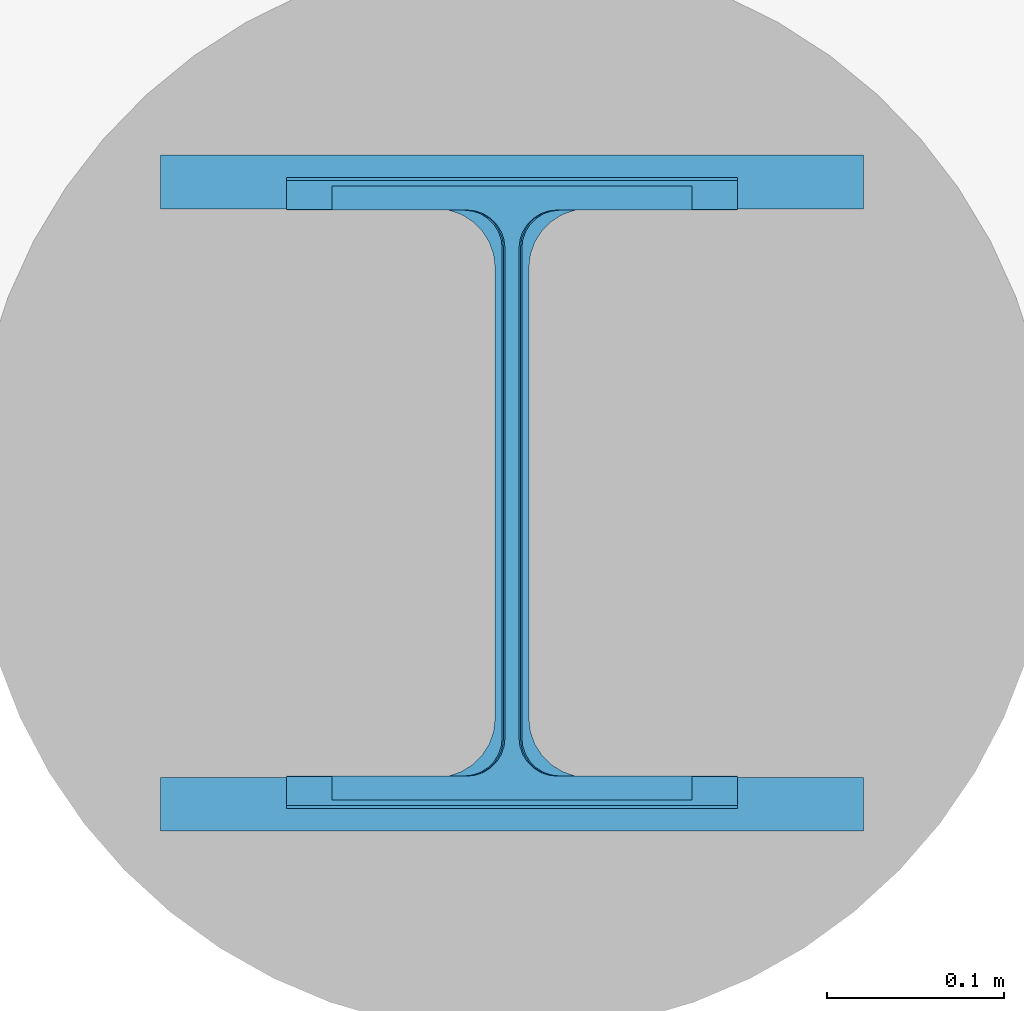
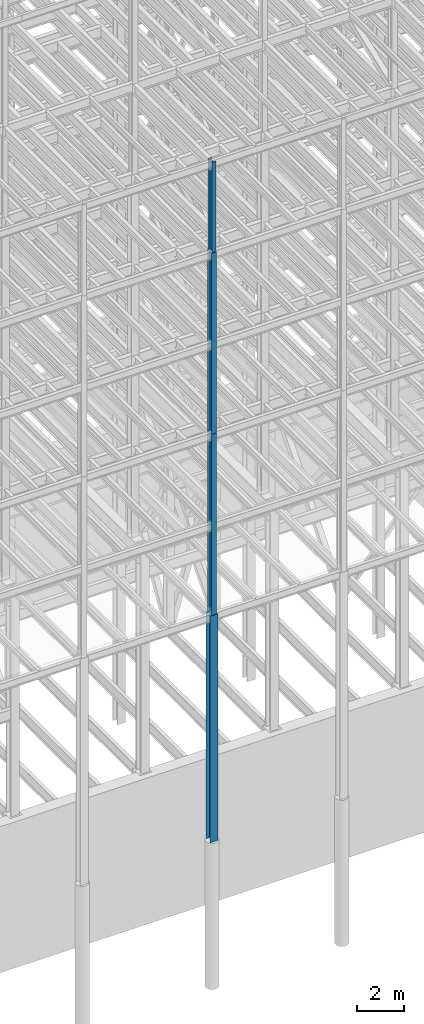
# One storey, part 70 of 150: 4 columns.
"""IFC2X3 building model written with IfcOpenShell, lengths in millimetres."""

from ifc_helpers import new_model, si_unit, frame, origin_with_axes, origin_2d_with_axis, place, context, subcontext, project, spatial, i_section, extrude, material, type_object, element, save


model = new_model("IFC2X3")

# Units and contexts
model_context = context("Model", 3, precision=1e-05, world=origin_with_axes())
body_context = subcontext(model_context, "Body", "Model", "MODEL_VIEW")
ifc_project = project(units=[si_unit("LENGTHUNIT", "METRE", prefix="MILLI"), si_unit("AREAUNIT", "SQUARE_METRE"), si_unit("VOLUMEUNIT", "CUBIC_METRE"), si_unit("MASSUNIT", "GRAM", prefix="KILO"), si_unit("TIMEUNIT", "SECOND"), si_unit("PLANEANGLEUNIT", "RADIAN"), si_unit("SOLIDANGLEUNIT", "STERADIAN"), si_unit("THERMODYNAMICTEMPERATUREUNIT", "DEGREE_CELSIUS"), si_unit("LUMINOUSINTENSITYUNIT", "LUMEN")], contexts=[model_context])

# Site, building, storey
site_placement = place(None, origin_with_axes())
site = spatial("IfcSite", under=ifc_project, at=site_placement, CompositionType="ELEMENT")
building_placement = place(site_placement, origin_with_axes())
building = spatial("IfcBuilding", under=site, at=building_placement, Name="Undefined", CompositionType="ELEMENT")
storey_placement = place(building_placement, origin_with_axes())
storey = spatial("IfcBuildingStorey", under=building, at=storey_placement, Name="Undefined", CompositionType="ELEMENT", Elevation=0.0)

# Columns
ifc_material = material(Name="STEEL/A992")
column_type_1 = type_object("IfcColumnType", Name="W14X43", PredefinedType="NOTDEFINED")
column_1_placement = place(storey_placement, frame((62992.0, 3454.4, 54483.0), z_axis=(0.0, 0.0, 1.0), x_axis=(1.0, 0.0, 0.0)))
element("IfcColumn", 1, at=column_1_placement, inside=storey, type_object=column_type_1, material=ifc_material, Name="COLUMN", ObjectType="W14X43", context=body_context, shape_type="SweptSolid", body=[
    extrude(i_section(OverallWidth=203.2, OverallDepth=346.075, WebThickness=7.9375, FlangeThickness=13.462, FilletRadius=21.4629, at=origin_2d_with_axis()), frame((0.0, 0.0, 4724.39999999999), z_axis=(0.0, 0.0, -1.0), x_axis=(-1.0, 0.0, 0.0)), (0.0, 0.0, 1.0), 4724.4),
])
column_type_2 = type_object("IfcColumnType", Name="W14X61", PredefinedType="NOTDEFINED")
column_2_placement = place(storey_placement, frame((62992.0, 3454.4, 45034.2), z_axis=(0.0, 0.0, 1.0), x_axis=(1.0, 0.0, 0.0)))
element("IfcColumn", 2, at=column_2_placement, inside=storey, type_object=column_type_2, material=ifc_material, Name="COLUMN", ObjectType="W14X61", context=body_context, shape_type="SweptSolid", body=[
    extrude(i_section(OverallWidth=254.0, OverallDepth=352.425, WebThickness=9.5249, FlangeThickness=16.383, FilletRadius=21.717, at=origin_2d_with_axis()), frame((0.0, 0.0, 9448.8), z_axis=(0.0, 0.0, -1.0), x_axis=(-1.0, 0.0, 0.0)), (0.0, 0.0, 1.0), 9448.8),
])
column_type_3 = type_object("IfcColumnType", Name="W14X68", PredefinedType="NOTDEFINED")
column_3_placement = place(storey_placement, frame((62992.0, 3454.4, 35585.4), z_axis=(0.0, 0.0, 1.0), x_axis=(1.0, 0.0, 0.0)))
element("IfcColumn", 3, at=column_3_placement, inside=storey, type_object=column_type_3, material=ifc_material, Name="COLUMN", ObjectType="W14X68", context=body_context, shape_type="SweptSolid", body=[
    extrude(i_section(OverallWidth=254.0, OverallDepth=355.6, WebThickness=11.1125, FlangeThickness=18.288, FilletRadius=21.3994, at=origin_2d_with_axis()), frame((0.0, 0.0, 9448.8), z_axis=(0.0, 0.0, -1.0), x_axis=(-1.0, 0.0, 0.0)), (0.0, 0.0, 1.0), 9448.8),
])
column_type_4 = type_object("IfcColumnType", Name="W14X159", PredefinedType="NOTDEFINED")
column_4_placement = place(storey_placement, frame((62992.0, 3454.4, 23774.4), z_axis=(0.0, 0.0, 1.0), x_axis=(1.0, 0.0, 0.0)))
element("IfcColumn", 4, at=column_4_placement, inside=storey, type_object=column_type_4, material=ifc_material, Name="COLUMN", ObjectType="W14X159", context=body_context, shape_type="SweptSolid", body=[
    extrude(i_section(OverallWidth=396.24, OverallDepth=381.0, WebThickness=19.0499, FlangeThickness=30.226, FilletRadius=33.2739, at=origin_2d_with_axis()), frame((0.0, 0.0, 11810.9988189), z_axis=(0.0, 0.0, -1.0), x_axis=(-1.0, 0.0, 0.0)), (0.0, 0.0, 1.0), 11810.9988189),
])

save(model, "model.ifc")
